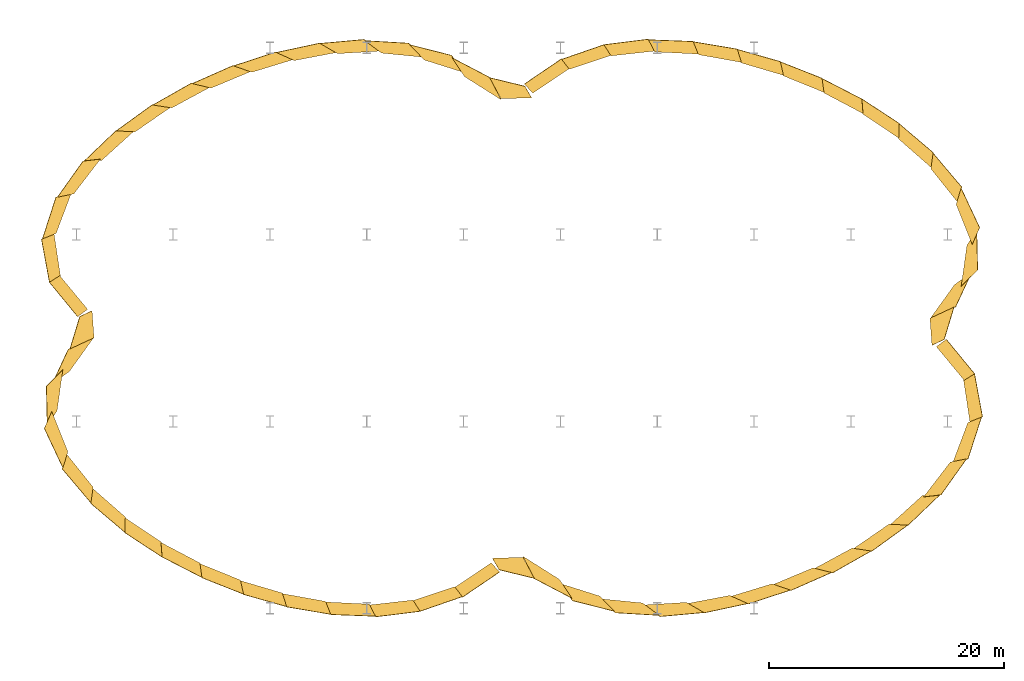
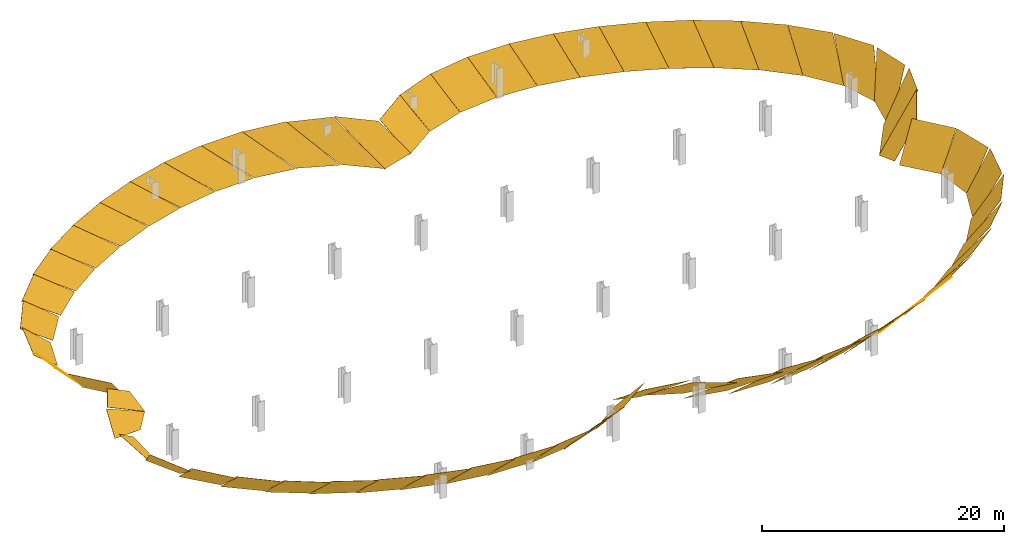
# One storey, part 2 of 2: 60 windows.
"""IFC2X3 building model written with IfcOpenShell, lengths in metres."""

from ifc_helpers import new_model, si_unit, direction, frame, origin_with_axes, place, context, project, spatial, polyline, outline, extrude, element, save


model = new_model("IFC2X3")

# Units and contexts
model_context = context("Model", 3, precision=1e-05, world=origin_with_axes(), true_north=direction((0.0, 1.0, 0.0)), identifier="Body")
ifc_project = project(units=[si_unit("LENGTHUNIT", "METRE"), si_unit("AREAUNIT", "SQUARE_METRE"), si_unit("VOLUMEUNIT", "CUBIC_METRE"), si_unit("PLANEANGLEUNIT", "RADIAN")], contexts=[model_context])

# Site, building, storey
site_placement = place(None, origin_with_axes())
site = spatial("IfcSite", under=ifc_project, at=site_placement, CompositionType="ELEMENT")
building_placement = place(None, origin_with_axes())
building = spatial("IfcBuilding", under=site, at=building_placement, Name="GH DEMO", CompositionType="ELEMENT")
storey_placement = place(None, origin_with_axes())
storey = spatial("IfcBuildingStorey", under=building, at=storey_placement, Name="Ground", CompositionType="ELEMENT")

# Windows
window_1_placement = place(None, origin_with_axes())
element("IfcWindow", 1, at=window_1_placement, inside=storey, context=model_context, shape_type="SweptSolid", body=[
    extrude(outline(polyline([(0.0, 0.0), (3.96911615145321, 0.0), (3.62052311964651, 3.9021190130649), (-0.38205964727439, 3.70217442874201), (0.0, 0.0)])), frame((1.76478576322882, 19.9512654630556, 0.0102044546149691), z_axis=(-0.42381889, 0.62393833, -0.6565657), x_axis=(-0.44620504, 0.48699541, 0.75082391)), (0.0, 0.0, 1.0), 0.02),
])
window_2_placement = place(None, origin_with_axes())
element("IfcWindow", 2, at=window_2_placement, inside=storey, context=model_context, shape_type="SweptSolid", body=[
    extrude(outline(polyline([(0.0, 0.0), (4.00707456237137, 0.0), (3.21358925587304, 3.83925314308381), (-0.868262407023305, 3.62421825645994), (0.0, 0.0)])), frame((4.86872691082287, 21.9926433336593, 0.0235692605761753), z_axis=(-0.24645629, 0.71386362, -0.65548305), x_axis=(-0.41384012, 0.53406497, 0.73723196)), (0.0, 0.0, -1.0), 0.02),
])
window_3_placement = place(None, origin_with_axes())
element("IfcWindow", 3, at=window_3_placement, inside=storey, context=model_context, shape_type="SweptSolid", body=[
    extrude(outline(polyline([(0.0, 0.0), (4.08731720725378, 0.0), (2.97927249232103, 3.76376277873931), (-1.17859366481879, 3.53971633834896), (0.0, 0.0)])), frame((8.41652832873377, 23.1152358014564, 0.0265430958751184), z_axis=(-0.09318245, 0.75000169, -0.65483929), x_axis=(-0.37306953, 0.58348381, 0.72136383)), (0.0, 0.0, 1.0), 0.02),
])
window_4_placement = place(None, origin_with_axes())
element("IfcWindow", 4, at=window_4_placement, inside=storey, context=model_context, shape_type="SweptSolid", body=[
    extrude(outline(polyline([(0.0, 0.0), (4.16393532791443, 0.0), (2.85770371544066, 3.70188773345208), (-1.3576743800539, 3.47731731322851), (0.0, 0.0)])), frame((12.1263507282959, 23.4720011028211, 0.0249739777391095), z_axis=(0.02845115, 0.75537613, -0.65467353), x_axis=(-0.32405371, 0.62653785, 0.70882968)), (0.0, 0.0, -1.0), 0.02),
])
window_5_placement = place(None, origin_with_axes())
element("IfcWindow", 5, at=window_5_placement, inside=storey, context=model_context, shape_type="SweptSolid", body=[
    extrude(outline(polyline([(0.0, 0.0), (4.2214265926936, 0.0), (2.7938764088117, 3.65810974620828), (-1.46156935709496, 3.43615155009285), (0.0, 0.0)])), frame((15.8490855585814, 23.235116282552, 0.0227440347088273), z_axis=(0.12553126, 0.74540169, -0.65468941), x_axis=(-0.27079642, 0.66059497, 0.70020253)), (0.0, 0.0, -1.0), 0.02),
])
window_6_placement = place(None, origin_with_axes())
element("IfcWindow", 6, at=window_6_placement, inside=storey, context=model_context, shape_type="SweptSolid", body=[
    extrude(outline(polyline([(0.0, 0.0), (4.26126914670795, 0.0), (2.75769410209025, 3.6281968283979), (-1.52618895569291, 3.40851280067894), (0.0, 0.0)])), frame((19.5134604048492, 22.5280219586852, 0.0212268695601479), z_axis=(0.20646636, 0.72708627, -0.654765), x_axis=(-0.21573487, 0.68654289, 0.69434669)), (0.0, 0.0, -1.0), 0.02),
])
window_7_placement = place(None, origin_with_axes())
element("IfcWindow", 7, at=window_7_placement, inside=storey, context=model_context, shape_type="SweptSolid", body=[
    extrude(outline(polyline([(0.0, 0.0), (4.2895023693168, 0.0), (2.73348720022925, 3.60629088261536), (-1.57394783481642, 3.38689650728034), (0.0, 0.0)])), frame((23.0803194384405, 21.4276737501823, 0.020897129916365), z_axis=(0.27797774, 0.70275341, -0.65487862), x_axis=(-0.15961366, 0.70606224, 0.68992724)), (0.0, 0.0, -1.0), 0.02),
])
window_8_placement = place(None, origin_with_axes())
element("IfcWindow", 8, at=window_8_placement, inside=storey, context=model_context, shape_type="SweptSolid", body=[
    extrude(outline(polyline([(0.0, 0.0), (4.31293992770742, 0.0), (2.71171777968288, 3.58637139389835), (-1.62197029557681, 3.36394073275141), (0.0, 0.0)])), frame((26.5193844529392, 19.9762286581454, 0.0221848923489288), z_axis=(0.34540967, 0.67200502, -0.65505832), x_axis=(-0.10207809, 0.72078236, 0.685604)), (0.0, 0.0, -1.0), 0.02),
])
window_9_placement = place(None, origin_with_axes())
element("IfcWindow", 9, at=window_9_placement, inside=storey, context=model_context, shape_type="SweptSolid", body=[
    extrude(outline(polyline([(0.0, 0.0), (4.33917929046627, 0.0), (2.68470229770254, 3.5616040663079), (-1.68846619945938, 3.33023122472228), (0.0, 0.0)])), frame((29.7952956642078, 18.1881873472633, 0.0260510574177197), z_axis=(0.41362904, 0.63195261, -0.65539829), x_axis=(-0.04170564, 0.73226153, 0.67974532)), (0.0, 0.0, 1.0), 0.02),
])
window_10_placement = place(None, origin_with_axes())
element("IfcWindow", 10, at=window_10_placement, inside=storey, context=model_context, shape_type="SweptSolid", body=[
    extrude(outline(polyline([(0.0, 0.0), (4.37869757868599, 0.0), (2.64464377705787, 3.52207448630493), (-1.80059423657388, 3.26851374094798), (0.0, 0.0)])), frame((32.85247299422, 16.0513341699736, 0.0351372222313821), z_axis=(0.48798799, 0.57557203, -0.65618942), x_axis=(0.02496488, 0.74226652, 0.66963958)), (0.0, 0.0, 1.0), 0.02),
])
window_11_placement = place(None, origin_with_axes())
element("IfcWindow", 11, at=window_11_placement, inside=storey, context=model_context, shape_type="SweptSolid", body=[
    extrude(outline(polyline([(0.0, 0.0), (4.45035958440003, 0.0), (2.58465343053809, 3.44965850370031), (-2.01144648162822, 3.1342029077479), (0.0, 0.0)])), frame((35.5835435422717, 13.5208259177041, 0.0580848032284845), z_axis=(0.57479405, 0.48572603, -0.65854538), x_axis=(0.10730417, 0.75308512, 0.64911372)), (0.0, 0.0, 1.0), 0.02),
])
window_12_placement = place(None, origin_with_axes())
element("IfcWindow", 12, at=window_12_placement, inside=storey, context=model_context, shape_type="SweptSolid", body=[
    extrude(outline(polyline([(0.0, 0.0), (4.59527679775588, 0.0), (2.51486662475589, 3.30669579514015), (-2.43514440297789, 2.76624161517645), (0.0, 0.0)])), frame((37.731365974218, 10.5133093825187, 0.130513336182796), z_axis=(0.67343925, 0.31660985, -0.66801032), x_axis=(0.23587129, 0.76437994, 0.60007336)), (0.0, 0.0, 1.0), 0.02),
])
window_13_placement = place(None, origin_with_axes())
element("IfcWindow", 13, at=window_13_placement, inside=storey, context=model_context, shape_type="SweptSolid", body=[
    extrude(outline(polyline([(0.0, 0.0), (4.92504634904477, 0.0), (2.54727333009491, 3.04700022428128), (-3.06308896578316, 1.84107219297715), (0.0, 0.0)])), frame((38.6473039185819, 7.03678632092952, 0.328816685521653), z_axis=(0.71191353, 0.01639402, -0.70207575), x_axis=(0.47182559, 0.72931001, 0.49546697)), (0.0, 0.0, 1.0), 0.02),
])
window_14_placement = place(None, origin_with_axes())
element("IfcWindow", 14, at=window_14_placement, inside=storey, context=model_context, shape_type="SweptSolid", body=[
    extrude(outline(polyline([(0.0, 0.0), (5.70743682449407, 0.0), (3.00874763865715, 2.75442591835674), (-3.33540996930574, 1.41249233392601), (0.0, 0.0)])), frame((37.5947882160094, 3.68405714494903, 0.362781628421654), z_axis=(0.6263192, -0.29148312, -0.72302272), x_axis=(0.73428916, 0.53206105, 0.42158092)), (0.0, 0.0, 1.0), 0.02),
])
window_15_placement = place(None, origin_with_axes())
element("IfcWindow", 15, at=window_15_placement, inside=storey, context=model_context, shape_type="SweptSolid", body=[
    extrude(outline(polyline([(0.0, 0.0), (6.46959084789981, 0.0), (3.53223677633045, 2.38984754679997), (-0.284852096613652, 2.39614243139651), (0.0, 0.0)])), frame((35.5067201195309, 0.827082846785855, -0.268837680877004), z_axis=(0.63071063, -0.19149532, -0.75201971), x_axis=(0.75926036, 0.35258007, 0.54700182)), (0.0, 0.0, 1.0), 0.02),
])
window_16_placement = place(None, origin_with_axes())
element("IfcWindow", 16, at=window_16_placement, inside=storey, context=model_context, shape_type="SweptSolid", body=[
    extrude(outline(polyline([(0.0, 0.0), (4.00599640128593, 0.0), (4.11075008549536, 3.90699227100322), (0.139461518254798, 3.70670060376298), (0.0, 0.0)])), frame((36.0646969025375, -1.57868973623812, -0.00789951064921479), z_axis=(0.58194061, 0.47802606, -0.65790289), x_axis=(0.52837729, 0.39272308, 0.75271909)), (0.0, 0.0, -1.0), 0.02),
])
window_17_placement = place(None, origin_with_axes())
element("IfcWindow", 17, at=window_17_placement, inside=storey, context=model_context, shape_type="SweptSolid", body=[
    extrude(outline(polyline([(0.0, 0.0), (3.97169583873489, 0.0), (3.18127648850557, 3.80455674202867), (-1.0576570225153, 3.50375220331262), (0.0, 0.0)])), frame((38.3633061658069, -4.44390818980108, 0.0669494457115195), z_axis=(0.73290798, 0.13528314, -0.6667416), x_axis=(0.59174158, 0.35680834, 0.72286216)), (0.0, 0.0, 1.0), 0.02),
])
window_18_placement = place(None, origin_with_axes())
element("IfcWindow", 18, at=window_18_placement, inside=storey, context=model_context, shape_type="SweptSolid", body=[
    extrude(outline(polyline([(0.0, 0.0), (4.24199250596491, 0.0), (2.58371727702798, 3.52226507601752), (-2.01342980103643, 3.10636791070042), (0.0, 0.0)])), frame((38.7286063452226, -8.03458759463613, 0.107953683275169), z_axis=(0.71518581, -0.23135264, -0.65953408), x_axis=(0.69819877, 0.27976455, 0.65897669)), (0.0, 0.0, 1.0), 0.02),
])
window_19_placement = place(None, origin_with_axes())
element("IfcWindow", 19, at=window_19_placement, inside=storey, context=model_context, shape_type="SweptSolid", body=[
    extrude(outline(polyline([(0.0, 0.0), (4.61793390783132, 0.0), (2.51688879751477, 3.30135623247442), (-2.31106154486776, 2.91835156795587), (0.0, 0.0)])), frame((37.2422283488924, -11.4044034355295, 0.0819124692959122), z_axis=(0.61446056, -0.43645141, -0.6572278), x_axis=(0.77158082, 0.15861549, 0.6160391)), (0.0, 0.0, -1.0), 0.02),
])
window_20_placement = place(None, origin_with_axes())
element("IfcWindow", 20, at=window_20_placement, inside=storey, context=model_context, shape_type="SweptSolid", body=[
    extrude(outline(polyline([(0.0, 0.0), (4.84469380915658, 0.0), (2.54919103247352, 3.17969641735649), (-2.40840184578106, 2.84761413346875), (0.0, 0.0)])), frame((34.8611019948263, -14.2560256975404, 0.0602116071222208), z_axis=(0.52111465, -0.5453556, -0.65652631), x_axis=(0.80178556, 0.04914851, 0.59558739)), (0.0, 0.0, -1.0), 0.02),
])
window_21_placement = place(None, origin_with_axes())
element("IfcWindow", 21, at=window_21_placement, inside=storey, context=model_context, shape_type="SweptSolid", body=[
    extrude(outline(polyline([(0.0, 0.0), (4.96934505268021, 0.0), (2.57962194009093, 3.11347514225658), (-2.45228029502536, 2.81330667463963), (0.0, 0.0)])), frame((32.0198207599102, -16.6654024639214, 0.0484635117215876), z_axis=(0.44235707, -0.61131252, -0.65621432), x_axis=(0.80988359, -0.0420127, 0.58508419)), (0.0, 0.0, 1.0), 0.02),
])
window_22_placement = place(None, origin_with_axes())
element("IfcWindow", 22, at=window_22_placement, inside=storey, context=model_context, shape_type="SweptSolid", body=[
    extrude(outline(polyline([(0.0, 0.0), (5.04104116276037, 0.0), (2.60015354303875, 3.07510409315101), (-2.47939245429975, 2.7907344437391), (0.0, 0.0)])), frame((28.8947518298289, -18.7000415867488, 0.0429537895886688), z_axis=(0.37212951, -0.65653191, -0.65611392), x_axis=(0.80636705, -0.12139601, 0.57882224)), (0.0, 0.0, 1.0), 0.02),
])
window_23_placement = place(None, origin_with_axes())
element("IfcWindow", 23, at=window_23_placement, inside=storey, context=model_context, shape_type="SweptSolid", body=[
    extrude(outline(polyline([(0.0, 0.0), (5.08743720332728, 0.0), (2.61415496261535, 3.04960751966114), (-2.50406195440843, 2.76886083867947), (0.0, 0.0)])), frame((25.5701727780974, -20.3920251585278, 0.0416244762612105), z_axis=(0.3046783, -0.6903635, -0.65617785), x_axis=(0.79536745, -0.19459576, 0.57404104)), (0.0, 0.0, -1.0), 0.02),
])
window_24_placement = place(None, origin_with_axes())
element("IfcWindow", 24, at=window_24_placement, inside=storey, context=model_context, shape_type="SweptSolid", body=[
    extrude(outline(polyline([(0.0, 0.0), (5.12561447220183, 0.0), (2.62579710278277, 3.02768858642175), (-2.53562443259483, 2.73939498036394), (0.0, 0.0)])), frame((22.0935702387912, -21.7444783201991, 0.0438941579898978), z_axis=(0.23501387, -0.71684913, -0.65642655), x_axis=(0.77822034, -0.26585274, 0.56894238)), (0.0, 0.0, -1.0), 0.02),
])
window_25_placement = place(None, origin_with_axes())
element("IfcWindow", 25, at=window_25_placement, inside=storey, context=model_context, shape_type="SweptSolid", body=[
    extrude(outline(polyline([(0.0, 0.0), (5.16882387520603, 0.0), (2.63951493088099, 3.00213688482952), (-2.58326140165727, 2.69278417672239), (0.0, 0.0)])), frame((18.4979584478669, -22.7340672197553, 0.0503453539659504), z_axis=(0.15801153, -0.73717808, -0.65696335), x_axis=(0.75457982, -0.33898827, 0.56186853)), (0.0, 0.0, -1.0), 0.02),
])
window_26_placement = place(None, origin_with_axes())
element("IfcWindow", 26, at=window_26_placement, inside=storey, context=model_context, shape_type="SweptSolid", body=[
    extrude(outline(polyline([(0.0, 0.0), (5.23059545724838, 0.0), (2.66148808620892, 2.96592725651863), (-2.65819161456323, 2.6148176836917), (0.0, 0.0)])), frame((14.8157712394439, -23.3072873664573, 0.0630039070442698), z_axis=(0.06749053, -0.74993563, -0.65805895), x_axis=(0.72225795, -0.41830641, 0.55078417)), (0.0, 0.0, 1.0), 0.02),
])
window_27_placement = place(None, origin_with_axes())
element("IfcWindow", 27, at=window_27_placement, inside=storey, context=model_context, shape_type="SweptSolid", body=[
    extrude(outline(polyline([(0.0, 0.0), (5.32831435804272, 0.0), (2.70278552422461, 2.91133473283927), (-2.77397468106435, 2.48216689747773), (0.0, 0.0)])), frame((11.0957977017634, -23.3706467473721, 0.0862609943422985), z_axis=(-0.0442153, -0.74961254, -0.6603984), x_axis=(0.67583012, -0.50927049, 0.53282006)), (0.0, 0.0, -1.0), 0.02),
])
window_28_placement = place(None, origin_with_axes())
element("IfcWindow", 28, at=window_28_placement, inside=storey, context=model_context, shape_type="SweptSolid", body=[
    extrude(outline(polyline([(0.0, 0.0), (5.48686761116738, 0.0), (2.78496430737077, 2.8309186308061), (-2.9391356715839, 2.2616287128042), (0.0, 0.0)])), frame((7.43522702826089, -22.7799698013809, 0.127325662910184), z_axis=(-0.18361359, -0.72332366, -0.66564926), x_axis=(0.60359127, -0.61743303, 0.50443436)), (0.0, 0.0, -1.0), 0.02),
])
window_29_placement = place(None, origin_with_axes())
element("IfcWindow", 29, at=window_29_placement, inside=storey, context=model_context, shape_type="SweptSolid", body=[
    extrude(outline(polyline([(0.0, 0.0), (5.74112724566602, 0.0), (2.94413807415295, 2.72345062093455), (-3.11947604414144, 1.97853537941212), (0.0, 0.0)])), frame((4.02772008298152, -21.370251813152, 0.178749696890219), z_axis=(-0.34181005, -0.65371514, -0.67514621), x_axis=(0.48733135, -0.73757194, 0.46743532)), (0.0, 0.0, -1.0), 0.02),
])
window_30_placement = place(None, origin_with_axes())
element("IfcWindow", 30, at=window_30_placement, inside=storey, context=model_context, shape_type="SweptSolid", body=[
    extrude(outline(polyline([(0.0, 0.0), (6.07910327909484, 0.0), (3.23403631993609, 2.51155667746774), (-0.555531768602983, 2.62923973651593), (0.0, 0.0)])), frame((0.93751498665819, -19.4901945650612, -0.249874708304711), z_axis=(-0.16292548, -0.67043674, -0.72385762), x_axis=(0.38524235, -0.71865059, 0.57890385)), (0.0, 0.0, -1.0), 0.02),
])
window_31_placement = place(None, origin_with_axes())
element("IfcWindow", 31, at=window_31_placement, inside=storey, context=model_context, shape_type="SweptSolid", body=[
    extrude(outline(polyline([(0.0, 0.0), (3.96911615145321, 0.0), (3.62052311964651, 3.9021190130649), (-0.38205964727439, 3.70217442874201), (0.0, 0.0)])), frame((-1.76478574280022, -19.9512654924238, 0.0102044228968798), z_axis=(0.42381888, -0.62393836, -0.65656568), x_axis=(0.44620503, -0.48699539, 0.75082392)), (0.0, 0.0, 1.0), 0.02),
])
window_32_placement = place(None, origin_with_axes())
element("IfcWindow", 32, at=window_32_placement, inside=storey, context=model_context, shape_type="SweptSolid", body=[
    extrude(outline(polyline([(0.0, 0.0), (4.00707456237137, 0.0), (3.21358925587304, 3.83925314308381), (-0.868262407023305, 3.62421825645994), (0.0, 0.0)])), frame((-4.86872689162651, -21.9926433852437, 0.0235692138661941), z_axis=(0.24645625, -0.71386362, -0.65548306), x_axis=(0.41383965, -0.53406524, 0.73723203)), (0.0, 0.0, -1.0), 0.02),
])
window_33_placement = place(None, origin_with_axes())
element("IfcWindow", 33, at=window_33_placement, inside=storey, context=model_context, shape_type="SweptSolid", body=[
    extrude(outline(polyline([(0.0, 0.0), (4.08731720725378, 0.0), (2.97927249232103, 3.76376277873931), (-1.17859366481879, 3.53971633834896), (0.0, 0.0)])), frame((-8.4165283288322, -23.1152358010617, 0.0265430962405869), z_axis=(0.09318245, -0.75000169, -0.65483929), x_axis=(0.37306953, -0.58348381, 0.72136383)), (0.0, 0.0, 1.0), 0.02),
])
window_34_placement = place(None, origin_with_axes())
element("IfcWindow", 34, at=window_34_placement, inside=storey, context=model_context, shape_type="SweptSolid", body=[
    extrude(outline(polyline([(0.0, 0.0), (4.16393532791443, 0.0), (2.85770371544066, 3.70188773345208), (-1.3576743800539, 3.47731731322851), (0.0, 0.0)])), frame((-12.12635075781, -23.4720011027471, 0.0249739780161984), z_axis=(-0.02845115, -0.75537613, -0.65467353), x_axis=(0.32405372, -0.62653785, 0.70882968)), (0.0, 0.0, -1.0), 0.02),
])
window_35_placement = place(None, origin_with_axes())
element("IfcWindow", 35, at=window_35_placement, inside=storey, context=model_context, shape_type="SweptSolid", body=[
    extrude(outline(polyline([(0.0, 0.0), (4.2214265926936, 0.0), (2.7938764088117, 3.65810974620828), (-1.46156935709496, 3.43615155009285), (0.0, 0.0)])), frame((-15.8490855585413, -23.2351162825575, 0.0227440347086374), z_axis=(-0.12553126, -0.74540169, -0.65468941), x_axis=(0.27079642, -0.66059497, 0.70020253)), (0.0, 0.0, -1.0), 0.02),
])
window_36_placement = place(None, origin_with_axes())
element("IfcWindow", 36, at=window_36_placement, inside=storey, context=model_context, shape_type="SweptSolid", body=[
    extrude(outline(polyline([(0.0, 0.0), (4.26126914670795, 0.0), (2.75769410209025, 3.6281968283979), (-1.52618895569291, 3.40851280067894), (0.0, 0.0)])), frame((-19.5134604048634, -22.5280219586812, 0.0212268695605117), z_axis=(-0.20646636, -0.72708627, -0.654765), x_axis=(0.21573487, -0.68654289, 0.69434669)), (0.0, 0.0, -1.0), 0.02),
])
window_37_placement = place(None, origin_with_axes())
element("IfcWindow", 37, at=window_37_placement, inside=storey, context=model_context, shape_type="SweptSolid", body=[
    extrude(outline(polyline([(0.0, 0.0), (4.2895023693168, 0.0), (2.73348720022925, 3.60629088261536), (-1.57394783481642, 3.38689650728034), (0.0, 0.0)])), frame((-23.0803194384757, -21.4276737501697, 0.020897129916174), z_axis=(-0.27797774, -0.70275341, -0.65487862), x_axis=(0.15961366, -0.70606224, 0.68992724)), (0.0, 0.0, -1.0), 0.02),
])
window_38_placement = place(None, origin_with_axes())
element("IfcWindow", 38, at=window_38_placement, inside=storey, context=model_context, shape_type="SweptSolid", body=[
    extrude(outline(polyline([(0.0, 0.0), (4.31293992770742, 0.0), (2.71171777968288, 3.58637139389835), (-1.62197029557681, 3.36394073275141), (0.0, 0.0)])), frame((-26.5193844528859, -19.9762286581713, 0.0221848923486969), z_axis=(-0.34540967, -0.67200502, -0.65505832), x_axis=(0.10207809, -0.72078236, 0.685604)), (0.0, 0.0, -1.0), 0.02),
])
window_39_placement = place(None, origin_with_axes())
element("IfcWindow", 39, at=window_39_placement, inside=storey, context=model_context, shape_type="SweptSolid", body=[
    extrude(outline(polyline([(0.0, 0.0), (4.33917929046627, 0.0), (2.68470229770254, 3.5616040663079), (-1.68846619945938, 3.33023122472228), (0.0, 0.0)])), frame((-29.7952956642241, -18.1881873472529, 0.0260510574180298), z_axis=(-0.41362904, -0.63195261, -0.65539829), x_axis=(0.04170564, -0.73226153, 0.67974532)), (0.0, 0.0, 1.0), 0.02),
])
window_40_placement = place(None, origin_with_axes())
element("IfcWindow", 40, at=window_40_placement, inside=storey, context=model_context, shape_type="SweptSolid", body=[
    extrude(outline(polyline([(0.0, 0.0), (4.37869757868599, 0.0), (2.64464377705787, 3.52207448630493), (-1.80059423657388, 3.26851374094798), (0.0, 0.0)])), frame((-32.852472994234, -16.0513341699614, 0.0351372222322425), z_axis=(-0.48798799, -0.57557203, -0.65618942), x_axis=(-0.02496488, -0.74226652, 0.66963958)), (0.0, 0.0, 1.0), 0.02),
])
window_41_placement = place(None, origin_with_axes())
element("IfcWindow", 41, at=window_41_placement, inside=storey, context=model_context, shape_type="SweptSolid", body=[
    extrude(outline(polyline([(0.0, 0.0), (4.45035958440003, 0.0), (2.58465343053809, 3.44965850370031), (-2.01144648162822, 3.1342029077479), (0.0, 0.0)])), frame((-35.5835435423095, -13.5208259176615, 0.0580848032296723), z_axis=(-0.57479405, -0.48572603, -0.65854538), x_axis=(-0.10730417, -0.75308512, 0.64911372)), (0.0, 0.0, 1.0), 0.02),
])
window_42_placement = place(None, origin_with_axes())
element("IfcWindow", 42, at=window_42_placement, inside=storey, context=model_context, shape_type="SweptSolid", body=[
    extrude(outline(polyline([(0.0, 0.0), (4.59527679775588, 0.0), (2.51486662475589, 3.30669579514015), (-2.43514440297789, 2.76624161517645), (0.0, 0.0)])), frame((-37.7313659742233, -10.5133093825015, 0.130513336186395), z_axis=(-0.67343925, -0.31660985, -0.66801032), x_axis=(-0.23587129, -0.76437994, 0.60007336)), (0.0, 0.0, 1.0), 0.02),
])
window_43_placement = place(None, origin_with_axes())
element("IfcWindow", 43, at=window_43_placement, inside=storey, context=model_context, shape_type="SweptSolid", body=[
    extrude(outline(polyline([(0.0, 0.0), (4.92504634904477, 0.0), (2.54727333009491, 3.04700022428128), (-3.06308896578316, 1.84107219297715), (0.0, 0.0)])), frame((-38.6473039185899, -7.03678632088223, 0.328816685514606), z_axis=(-0.71191353, -0.01639402, -0.70207575), x_axis=(-0.47182559, -0.72931001, 0.49546697)), (0.0, 0.0, 1.0), 0.02),
])
window_44_placement = place(None, origin_with_axes())
element("IfcWindow", 44, at=window_44_placement, inside=storey, context=model_context, shape_type="SweptSolid", body=[
    extrude(outline(polyline([(0.0, 0.0), (5.70743682449407, 0.0), (3.00874763865715, 2.75442591835674), (-3.33540996930574, 1.41249233392601), (0.0, 0.0)])), frame((-37.5947882160118, -3.68405714495272, 0.362781628421601), z_axis=(-0.6263192, 0.29148312, -0.72302272), x_axis=(-0.73428916, -0.53206105, 0.42158092)), (0.0, 0.0, 1.0), 0.02),
])
window_45_placement = place(None, origin_with_axes())
element("IfcWindow", 45, at=window_45_placement, inside=storey, context=model_context, shape_type="SweptSolid", body=[
    extrude(outline(polyline([(0.0, 0.0), (6.46959084789981, 0.0), (3.53223677633045, 2.38984754679997), (-0.284852096613652, 2.39614243139651), (0.0, 0.0)])), frame((-35.5067201195309, -0.827082846785852, -0.268837680877016), z_axis=(-0.63071063, 0.19149532, -0.75201971), x_axis=(-0.75926036, -0.35258007, 0.54700182)), (0.0, 0.0, 1.0), 0.02),
])
window_46_placement = place(None, origin_with_axes())
element("IfcWindow", 46, at=window_46_placement, inside=storey, context=model_context, shape_type="SweptSolid", body=[
    extrude(outline(polyline([(0.0, 0.0), (4.00599640128593, 0.0), (4.11075008549536, 3.90699227100322), (0.139461518254798, 3.70670060376298), (0.0, 0.0)])), frame((-36.0646968549452, 1.5786897757413, -0.00789945724364407), z_axis=(-0.5819406, -0.47802602, -0.65790292), x_axis=(-0.52837731, -0.3927231, 0.75271906)), (0.0, 0.0, -1.0), 0.02),
])
window_47_placement = place(None, origin_with_axes())
element("IfcWindow", 47, at=window_47_placement, inside=storey, context=model_context, shape_type="SweptSolid", body=[
    extrude(outline(polyline([(0.0, 0.0), (3.97169583873489, 0.0), (3.18127648850557, 3.80455674202867), (-1.0576570225153, 3.50375220331262), (0.0, 0.0)])), frame((-38.3633067514158, 4.44390954001065, 0.0669494945176812), z_axis=(-0.73290804, -0.13528311, -0.66674154), x_axis=(-0.59174138, -0.35680873, 0.72286213)), (0.0, 0.0, 1.0), 0.02),
])
window_48_placement = place(None, origin_with_axes())
element("IfcWindow", 48, at=window_48_placement, inside=storey, context=model_context, shape_type="SweptSolid", body=[
    extrude(outline(polyline([(0.0, 0.0), (4.24199250596491, 0.0), (2.58371727702798, 3.52226507601752), (-2.01342980103643, 3.10636791070042), (0.0, 0.0)])), frame((-38.7286064651233, 8.03458761974944, 0.107953578054503), z_axis=(-0.71518578, 0.23135272, -0.65953409), x_axis=(-0.69819882, -0.27976415, 0.65897681)), (0.0, 0.0, 1.0), 0.02),
])
window_49_placement = place(None, origin_with_axes())
element("IfcWindow", 49, at=window_49_placement, inside=storey, context=model_context, shape_type="SweptSolid", body=[
    extrude(outline(polyline([(0.0, 0.0), (4.61793390783132, 0.0), (2.51688879751477, 3.30135623247442), (-2.31106154486776, 2.91835156795587), (0.0, 0.0)])), frame((-37.2422283489219, 11.4044034354996, 0.0819124692919735), z_axis=(-0.61446056, 0.43645141, -0.6572278), x_axis=(-0.77158082, -0.15861549, 0.6160391)), (0.0, 0.0, -1.0), 0.02),
])
window_50_placement = place(None, origin_with_axes())
element("IfcWindow", 50, at=window_50_placement, inside=storey, context=model_context, shape_type="SweptSolid", body=[
    extrude(outline(polyline([(0.0, 0.0), (4.84469380915658, 0.0), (2.54919103247352, 3.17969641735649), (-2.40840184578106, 2.84761413346875), (0.0, 0.0)])), frame((-34.8611019906999, 14.2560256921652, 0.0602116130175218), z_axis=(-0.52111464, 0.54535561, -0.65652631), x_axis=(-0.80178557, -0.04914851, 0.59558738)), (0.0, 0.0, -1.0), 0.02),
])
window_51_placement = place(None, origin_with_axes())
element("IfcWindow", 51, at=window_51_placement, inside=storey, context=model_context, shape_type="SweptSolid", body=[
    extrude(outline(polyline([(0.0, 0.0), (4.96934505268021, 0.0), (2.57962194009093, 3.11347514225658), (-2.45228029502536, 2.81330667463963), (0.0, 0.0)])), frame((-32.01982036072, 16.6654027464062, 0.0484635191069365), z_axis=(-0.44235706, 0.61131252, -0.65621432), x_axis=(-0.80988362, 0.04201264, 0.58508415)), (0.0, 0.0, 1.0), 0.02),
])
window_52_placement = place(None, origin_with_axes())
element("IfcWindow", 52, at=window_52_placement, inside=storey, context=model_context, shape_type="SweptSolid", body=[
    extrude(outline(polyline([(0.0, 0.0), (5.04104116276037, 0.0), (2.60015354303875, 3.07510409315101), (-2.47939245429975, 2.7907344437391), (0.0, 0.0)])), frame((-28.8947514741511, 18.700041788455, 0.042953791482063), z_axis=(-0.37212951, 0.65653191, -0.65611392), x_axis=(-0.80636708, 0.12139597, 0.57882221)), (0.0, 0.0, 1.0), 0.02),
])
window_53_placement = place(None, origin_with_axes())
element("IfcWindow", 53, at=window_53_placement, inside=storey, context=model_context, shape_type="SweptSolid", body=[
    extrude(outline(polyline([(0.0, 0.0), (5.08743720332728, 0.0), (2.61415496261535, 3.04960751966114), (-2.50406195440843, 2.76886083867947), (0.0, 0.0)])), frame((-25.5701727777555, 20.3920251577069, 0.0416244770447074), z_axis=(-0.3046783, 0.6903635, -0.65617785), x_axis=(-0.79536745, 0.19459576, 0.57404103)), (0.0, 0.0, -1.0), 0.02),
])
window_54_placement = place(None, origin_with_axes())
element("IfcWindow", 54, at=window_54_placement, inside=storey, context=model_context, shape_type="SweptSolid", body=[
    extrude(outline(polyline([(0.0, 0.0), (5.12561447220183, 0.0), (2.62579710278277, 3.02768858642175), (-2.53562443259483, 2.73939498036394), (0.0, 0.0)])), frame((-22.0935702388074, 21.7444783202409, 0.0438941579482616), z_axis=(-0.23501387, 0.71684913, -0.65642655), x_axis=(-0.77822034, 0.26585274, 0.56894238)), (0.0, 0.0, -1.0), 0.02),
])
window_55_placement = place(None, origin_with_axes())
element("IfcWindow", 55, at=window_55_placement, inside=storey, context=model_context, shape_type="SweptSolid", body=[
    extrude(outline(polyline([(0.0, 0.0), (5.16882387520603, 0.0), (2.63951493088099, 3.00213688482952), (-2.58326140165727, 2.69278417672239), (0.0, 0.0)])), frame((-18.4979584477948, 22.7340672192689, 0.0503453544004146), z_axis=(-0.15801153, 0.73717808, -0.65696335), x_axis=(-0.75457983, 0.33898827, 0.56186853)), (0.0, 0.0, -1.0), 0.02),
])
window_56_placement = place(None, origin_with_axes())
element("IfcWindow", 56, at=window_56_placement, inside=storey, context=model_context, shape_type="SweptSolid", body=[
    extrude(outline(polyline([(0.0, 0.0), (5.23059545724838, 0.0), (2.66148808620892, 2.96592725651863), (-2.65819161456323, 2.6148176836917), (0.0, 0.0)])), frame((-14.8157712392657, 23.307287366031, 0.063003907444514), z_axis=(-0.06749053, 0.74993563, -0.65805895), x_axis=(-0.72225796, 0.41830641, 0.55078417)), (0.0, 0.0, 1.0), 0.02),
])
window_57_placement = place(None, origin_with_axes())
element("IfcWindow", 57, at=window_57_placement, inside=storey, context=model_context, shape_type="SweptSolid", body=[
    extrude(outline(polyline([(0.0, 0.0), (5.32831435804272, 0.0), (2.70278552422461, 2.91133473283927), (-2.77397468106435, 2.48216689747773), (0.0, 0.0)])), frame((-11.0957977017203, 23.3706467476044, 0.0862609941245913), z_axis=(0.0442153, 0.74961254, -0.6603984), x_axis=(-0.67583012, 0.50927049, 0.53282006)), (0.0, 0.0, -1.0), 0.02),
])
window_58_placement = place(None, origin_with_axes())
element("IfcWindow", 58, at=window_58_placement, inside=storey, context=model_context, shape_type="SweptSolid", body=[
    extrude(outline(polyline([(0.0, 0.0), (5.48686761116738, 0.0), (2.78496430737077, 2.8309186308061), (-2.9391356715839, 2.2616287128042), (0.0, 0.0)])), frame((-7.43522702817025, 22.779969801345, 0.127325662923492), z_axis=(0.18361359, 0.72332366, -0.66564926), x_axis=(-0.60359127, 0.61743303, 0.50443436)), (0.0, 0.0, -1.0), 0.02),
])
window_59_placement = place(None, origin_with_axes())
element("IfcWindow", 59, at=window_59_placement, inside=storey, context=model_context, shape_type="SweptSolid", body=[
    extrude(outline(polyline([(0.0, 0.0), (5.74112724566602, 0.0), (2.94413807415295, 2.72345062093455), (-3.11947604414144, 1.97853537941212), (0.0, 0.0)])), frame((-4.02772008293038, 21.3702518131735, 0.178749696841484), z_axis=(0.34181005, 0.65371514, -0.67514621), x_axis=(-0.48733135, 0.73757194, 0.46743532)), (0.0, 0.0, -1.0), 0.02),
])
window_60_placement = place(None, origin_with_axes())
element("IfcWindow", 60, at=window_60_placement, inside=storey, context=model_context, shape_type="SweptSolid", body=[
    extrude(outline(polyline([(0.0, 0.0), (6.07910327909484, 0.0), (3.23403631993609, 2.51155667746774), (-0.555531768602983, 2.62923973651593), (0.0, 0.0)])), frame((-0.93751498665818, 19.4901945650612, -0.249874708304708), z_axis=(0.16292548, 0.67043674, -0.72385762), x_axis=(-0.38524235, 0.71865059, 0.57890385)), (0.0, 0.0, -1.0), 0.02),
])

save(model, "model.ifc")
